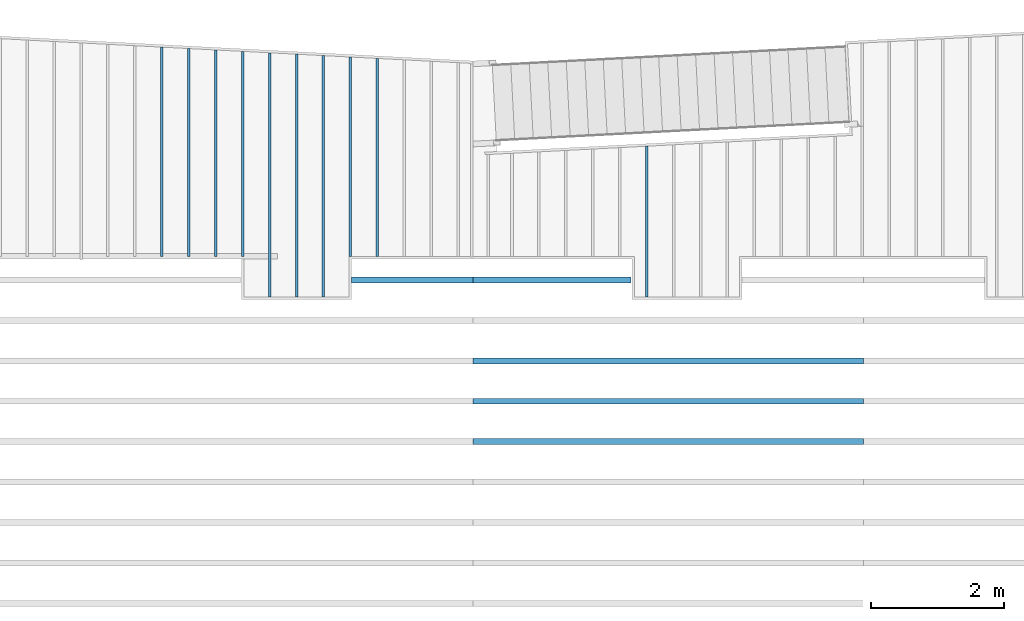
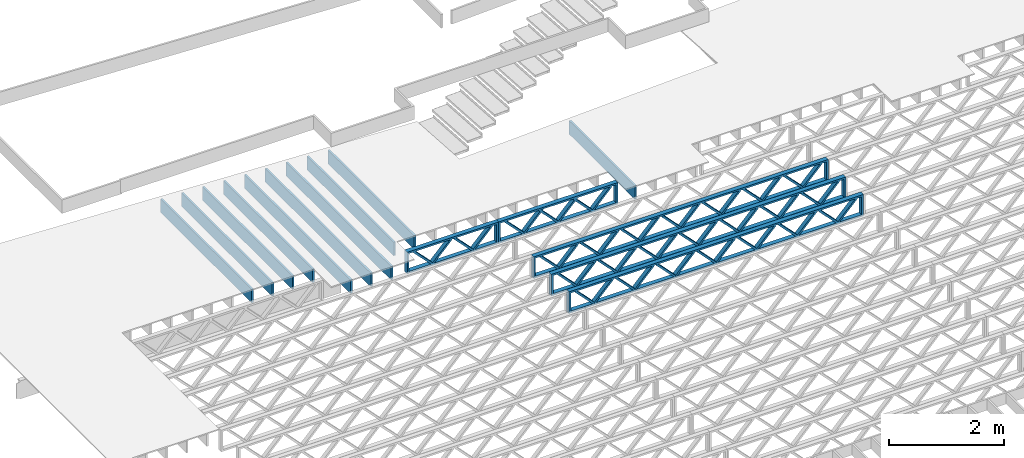
# One storey, part 4 of 23: 15 beams, 3 elements without a shape of their own.
"""IFC4 building model written with IfcOpenShell, lengths in feet."""

from ifc_helpers import new_model, entity, si_unit, converted_unit, derived_unit, direction, frame, frame_2d, origin, origin_2d_with_axis, place, context, subcontext, project, spatial, rectangle, extrude, source, transform, mapped, material, material_profile, profile_set, profile_usage, type_object, type_shapes, element, aggregate, save


model = new_model("IFC4")

# Units and contexts
model_context_1 = context("Model", 3, precision=0.0001, world=origin(), true_north=direction((6.12303176911189e-17, 1.0)))
model_context_2 = context("Model", 3, precision=0.0001, world=origin(), true_north=direction((6.12303176911189e-17, 1.0)))
body_context = subcontext(model_context_2, "Body", "Model", "MODEL_VIEW")
ifc_project = project(units=[converted_unit("LENGTHUNIT", "FOOT", entity("IfcRatioMeasure", 0.3048), si_unit("LENGTHUNIT", "METRE"), dimensions=[1, 0, 0, 0, 0, 0, 0]), converted_unit("AREAUNIT", "SQUARE FOOT", entity("IfcRatioMeasure", 0.09290304), si_unit("AREAUNIT", "SQUARE_METRE"), dimensions=[2, 0, 0, 0, 0, 0, 0]), converted_unit("VOLUMEUNIT", "CUBIC FOOT", entity("IfcRatioMeasure", 0.028316846592), si_unit("VOLUMEUNIT", "CUBIC_METRE"), dimensions=[3, 0, 0, 0, 0, 0, 0]), converted_unit("PLANEANGLEUNIT", "DEGREE", entity("IfcRatioMeasure", 0.0174532925199433), si_unit("PLANEANGLEUNIT", "RADIAN"), dimensions=[0, 0, 0, 0, 0, 0, 0]), si_unit("MASSUNIT", "GRAM", prefix="KILO"), derived_unit("MASSDENSITYUNIT", [(si_unit("MASSUNIT", "GRAM", prefix="KILO"), 1), (si_unit("LENGTHUNIT", "METRE"), -3)]), derived_unit("MOMENTOFINERTIAUNIT", [(si_unit("LENGTHUNIT", "METRE"), 4)]), si_unit("TIMEUNIT", "SECOND"), si_unit("FREQUENCYUNIT", "HERTZ"), si_unit("THERMODYNAMICTEMPERATUREUNIT", "DEGREE_CELSIUS"), derived_unit("THERMALTRANSMITTANCEUNIT", [(si_unit("MASSUNIT", "GRAM", prefix="KILO"), 1), (si_unit("THERMODYNAMICTEMPERATUREUNIT", "KELVIN"), -1), (si_unit("TIMEUNIT", "SECOND"), -3)]), derived_unit("VOLUMETRICFLOWRATEUNIT", [(si_unit("LENGTHUNIT", "METRE"), 3), (si_unit("TIMEUNIT", "SECOND"), -1)]), si_unit("ELECTRICCURRENTUNIT", "AMPERE"), si_unit("ELECTRICVOLTAGEUNIT", "VOLT"), si_unit("POWERUNIT", "WATT"), si_unit("FORCEUNIT", "NEWTON"), si_unit("ILLUMINANCEUNIT", "LUX"), si_unit("LUMINOUSFLUXUNIT", "LUMEN"), si_unit("LUMINOUSINTENSITYUNIT", "CANDELA"), derived_unit("USERDEFINED", [(si_unit("MASSUNIT", "GRAM", prefix="KILO"), -1), (si_unit("LENGTHUNIT", "METRE"), -2), (si_unit("TIMEUNIT", "SECOND"), 3), (si_unit("LUMINOUSFLUXUNIT", "LUMEN"), 1)]), derived_unit("LINEARVELOCITYUNIT", [(si_unit("LENGTHUNIT", "METRE"), 1), (si_unit("TIMEUNIT", "SECOND"), -1)]), si_unit("PRESSUREUNIT", "PASCAL"), derived_unit("USERDEFINED", [(si_unit("LENGTHUNIT", "METRE"), -2), (si_unit("MASSUNIT", "GRAM", prefix="KILO"), 1), (si_unit("TIMEUNIT", "SECOND"), -2)]), derived_unit("LINEARFORCEUNIT", [(si_unit("MASSUNIT", "GRAM", prefix="KILO"), 1), (si_unit("LENGTHUNIT", "METRE"), 1), (si_unit("TIMEUNIT", "SECOND"), -2), (si_unit("LENGTHUNIT", "METRE"), -1)]), derived_unit("PLANARFORCEUNIT", [(si_unit("MASSUNIT", "GRAM", prefix="KILO"), 1), (si_unit("LENGTHUNIT", "METRE"), 1), (si_unit("TIMEUNIT", "SECOND"), -2), (si_unit("LENGTHUNIT", "METRE"), -2)])], contexts=[model_context_1])

# Site, building, storey
site_placement = place(None, origin())
site = spatial("IfcSite", under=ifc_project, at=site_placement, CompositionType="ELEMENT")
building_placement = place(site_placement, origin())
building = spatial("IfcBuilding", under=site, at=building_placement, CompositionType="ELEMENT")
storey_placement = place(building_placement, frame((0.0, 0.0, 10.8020833333333)))
storey = spatial("IfcBuildingStorey", under=building, at=storey_placement, Name="2ND FLOOR", CompositionType="ELEMENT", Elevation=10.8020833333333)

# Assembly, beams
assembly_1_placement = place(storey_placement, origin())
assembly_1 = element("IfcElementAssembly", 1, at=assembly_1_placement, inside=storey, Name="Structural Beam System:Structural Framing System", ObjectType="Structural Beam System:Structural Framing System", AssemblyPlace="NOTDEFINED", PredefinedType="BEAM_GRID")
ifc_material_1 = material(Category="Materials")
ifc_material_profile_1 = material_profile(ifc_material_1, rectangle(XDim=0.9375, YDim=0.125000000000011, at=origin_2d_with_axis()))
ifc_profile_set_1 = profile_set([ifc_material_profile_1])
ifc_profile_usage_1 = profile_usage(ifc_profile_set_1, cardinal=8)
beam_type_1 = type_object("IfcBeamType", PredefinedType="BEAM", material=ifc_profile_set_1)
shared_shape_1 = source(origin(), body_context, "Body", "SweptSolid", [
    extrude(rectangle(XDim=0.9375, YDim=0.125000000000011, at=origin_2d_with_axis()), frame((-3.72929415572452, 0.0, 0.0), z_axis=(1.0, 0.0, 0.0), x_axis=(0.0, 0.0, -1.0)), (0.0, 0.0, 1.0), 7.45858831144903),
])
type_shapes(beam_type_1, [shared_shape_1])
beam_1_placement = place(assembly_1_placement, frame((-233.133993818795, 960.757895705042, -0.729166666666744), z_axis=(0.0, 0.0, 1.0), x_axis=(0.0, 1.0, 0.0)))
beam_1 = element("IfcBeam", 2, at=beam_1_placement, type_object=beam_type_1, material=ifc_profile_usage_1, PredefinedType="BEAM", context=body_context, shape_type="MappedRepresentation", body=[
    mapped(shared_shape_1, transform((0.0, 0.0, 0.0), scale=1.0)),
])
ifc_profile_usage_2 = profile_usage(ifc_profile_set_1, cardinal=8)
beam_type_2 = type_object("IfcBeamType", PredefinedType="BEAM", material=ifc_profile_set_1)
shared_shape_2 = source(origin(), body_context, "Body", "SweptSolid", [
    extrude(rectangle(XDim=0.9375, YDim=0.125000000000011, at=origin_2d_with_axis()), frame((-4.90124353989279, 0.0, 0.0), z_axis=(1.0, 0.0, 0.0), x_axis=(0.0, 0.0, -1.0)), (0.0, 0.0, 1.0), 9.80248707978558),
])
type_shapes(beam_type_2, [shared_shape_2])
beam_2_placement = place(assembly_1_placement, frame((-246.467327152129, 963.929847709559, -0.729166666666744), z_axis=(0.0, 0.0, 1.0), x_axis=(0.0, 1.0, 0.0)))
beam_2 = element("IfcBeam", 3, at=beam_2_placement, type_object=beam_type_2, material=ifc_profile_usage_2, PredefinedType="BEAM", context=body_context, shape_type="MappedRepresentation", body=[
    mapped(shared_shape_2, transform((0.0, 0.0, 0.0), scale=1.0)),
])
ifc_profile_usage_3 = profile_usage(ifc_profile_set_1, cardinal=8)
beam_type_3 = type_object("IfcBeamType", PredefinedType="BEAM", material=ifc_profile_set_1)
shared_shape_3 = source(origin(), body_context, "Body", "SweptSolid", [
    extrude(rectangle(XDim=0.9375, YDim=0.125000000000011, at=origin_2d_with_axis()), frame((-6.04099892815498, 0.0, 0.0), z_axis=(1.0, 0.0, 0.0), x_axis=(0.0, 0.0, -1.0)), (0.0, 0.0, 1.0), 12.08199785631),
])
type_shapes(beam_type_3, [shared_shape_3])
beam_3_placement = place(assembly_1_placement, frame((-251.800660485462, 963.069600477473, -0.729166666666744), z_axis=(0.0, 0.0, 1.0), x_axis=(0.0, 1.0, 0.0)))
beam_3 = element("IfcBeam", 4, at=beam_3_placement, type_object=beam_type_3, material=ifc_profile_usage_3, PredefinedType="BEAM", context=body_context, shape_type="MappedRepresentation", body=[
    mapped(shared_shape_3, transform((0.0, 0.0, 0.0), scale=1.0)),
])
ifc_profile_usage_4 = profile_usage(ifc_profile_set_1, cardinal=8)
beam_type_4 = type_object("IfcBeamType", PredefinedType="BEAM", material=ifc_profile_set_1)
shared_shape_4 = source(origin(), body_context, "Body", "SweptSolid", [
    extrude(rectangle(XDim=0.9375, YDim=0.125000000000011, at=origin_2d_with_axis()), frame((-5.11087465702491, 0.0, 0.0), z_axis=(1.0, 0.0, 0.0), x_axis=(0.0, 0.0, -1.0)), (0.0, 0.0, 1.0), 10.2217493140498),
])
type_shapes(beam_type_4, [shared_shape_4])
beam_4_placement = place(assembly_1_placement, frame((-254.467327152129, 964.139478826691, -0.729166666666744), z_axis=(0.0, 0.0, 1.0), x_axis=(0.0, 1.0, 0.0)))
beam_4 = element("IfcBeam", 5, at=beam_4_placement, type_object=beam_type_4, material=ifc_profile_usage_4, PredefinedType="BEAM", context=body_context, shape_type="MappedRepresentation", body=[
    mapped(shared_shape_4, transform((0.0, 0.0, 0.0), scale=1.0)),
])

assembly_2_placement = place(storey_placement, origin())
assembly_2 = element("IfcElementAssembly", 6, at=assembly_2_placement, inside=storey, Name="Structural Beam System:Structural Framing System", ObjectType="Structural Beam System:Structural Framing System", AssemblyPlace="NOTDEFINED", PredefinedType="BEAM_GRID")
ifc_material_2 = material(Name="WOOD TRUSS", Category="Materials")
ifc_material_profile_2 = material_profile(ifc_material_2, rectangle(XDim=1.73473973950632, YDim=0.125, at=frame_2d((-1.11022302462516e-16, 8.32667268468867e-17), x_axis=(1.0, 0.0))))
ifc_material_profile_3 = material_profile(ifc_material_2, rectangle(XDim=1.73473973950633, YDim=0.125, at=frame_2d((-1.11022302462516e-16, 8.32667268468867e-17), x_axis=(1.0, 0.0))))
ifc_material_profile_4 = material_profile(ifc_material_2, rectangle(XDim=1.73473973950632, YDim=0.125, at=frame_2d((-5.55111512312578e-17, 1.38777878078145e-16), x_axis=(1.0, 0.0))))
ifc_material_profile_5 = material_profile(ifc_material_2, rectangle(XDim=1.73473973950633, YDim=0.125, at=frame_2d((-1.11022302462516e-16, 8.32667268468867e-17), x_axis=(1.0, 0.0))))
ifc_material_profile_6 = material_profile(ifc_material_2, rectangle(XDim=1.73473973950632, YDim=0.125, at=frame_2d((-1.11022302462516e-16, 8.32667268468867e-17), x_axis=(1.0, 0.0))))
ifc_material_profile_7 = material_profile(ifc_material_2, rectangle(XDim=1.73473973950633, YDim=0.125, at=frame_2d((-2.77555756156289e-16, 3.05311331771918e-16), x_axis=(1.0, 0.0))))
ifc_material_profile_8 = material_profile(ifc_material_2, rectangle(XDim=1.73473973950632, YDim=0.124999999999999, at=frame_2d((-3.88578058618805e-16, -2.4980018054066e-16), x_axis=(1.0, 0.0))))
ifc_material_profile_9 = material_profile(ifc_material_2, rectangle(XDim=1.73473973950633, YDim=0.125, at=frame_2d((2.77555756156289e-16, -3.05311331771918e-16), x_axis=(1.0, 0.0))))
ifc_material_profile_10 = material_profile(ifc_material_2, rectangle(XDim=1.73473973950632, YDim=0.124999999999999, at=frame_2d((-1.11022302462516e-16, 8.32667268468867e-17), x_axis=(1.0, 0.0))))
ifc_material_profile_11 = material_profile(ifc_material_2, rectangle(XDim=1.73473973950633, YDim=0.125, at=origin_2d_with_axis()))
ifc_material_profile_12 = material_profile(ifc_material_2, rectangle(XDim=0.124999999999982, YDim=0.291666666666668, at=origin_2d_with_axis()))
ifc_material_profile_13 = material_profile(ifc_material_2, rectangle(XDim=0.124999999999932, YDim=0.291666666666664, at=origin_2d_with_axis()))
ifc_material_profile_14 = material_profile(ifc_material_2, rectangle(XDim=1.25000000000002, YDim=0.29166666666667, at=origin_2d_with_axis()))
ifc_material_profile_15 = material_profile(ifc_material_2, rectangle(XDim=1.25000000000004, YDim=0.291666666666667, at=origin_2d_with_axis()))
ifc_profile_set_2 = profile_set([ifc_material_profile_2, ifc_material_profile_3, ifc_material_profile_4, ifc_material_profile_5, ifc_material_profile_6, ifc_material_profile_7, ifc_material_profile_8, ifc_material_profile_9, ifc_material_profile_10, ifc_material_profile_11, ifc_material_profile_12, ifc_material_profile_13, ifc_material_profile_14, ifc_material_profile_15])
ifc_profile_usage_5 = profile_usage(ifc_profile_set_2, cardinal=8)
beam_type_5 = type_object("IfcBeamType", PredefinedType="BEAM", material=ifc_profile_set_2)
shared_shape_5 = source(origin(), body_context, "Body", "SweptSolid", [
    extrude(rectangle(XDim=1.73473973950632, YDim=0.124999999999999, at=frame_2d((5.55111512312578e-16, 7.21644966006352e-16), x_axis=(1.0, 0.0))), frame((5.95847627016997, -0.145833333333334, 0.0), z_axis=(0.0, 1.0, 0.0), x_axis=(0.693383046997606, 0.0, 0.720569184836762)), (0.0, 0.0, 1.0), 0.291666666666667),
    extrude(rectangle(XDim=1.73473973950633, YDim=0.125, at=origin_2d_with_axis()), frame((4.7081903964967, -0.145833333333334, 0.0), z_axis=(0.0, 1.0, 0.0), x_axis=(0.69338304699761, 0.0, -0.720569184836758)), (0.0, 0.0, 1.0), 0.291666666666666),
    extrude(rectangle(XDim=1.73473973950632, YDim=0.125, at=frame_2d((2.22044604925031e-16, 3.88578058618805e-16), x_axis=(1.0, 0.0))), frame((3.29180960350347, -0.145833333333334, 0.0), z_axis=(0.0, 1.0, 0.0), x_axis=(0.693383046997606, 0.0, 0.720569184836762)), (0.0, 0.0, 1.0), 0.291666666666667),
    extrude(rectangle(XDim=1.73473973950633, YDim=0.125, at=frame_2d((1.11022302462516e-16, -8.32667268468867e-17), x_axis=(1.0, 0.0))), frame((2.0415237298302, -0.145833333333334, 0.0), z_axis=(0.0, 1.0, 0.0), x_axis=(0.69338304699761, 0.0, -0.720569184836758)), (0.0, 0.0, 1.0), 0.291666666666667),
    extrude(rectangle(XDim=1.73473973950632, YDim=0.125, at=frame_2d((-5.55111512312578e-17, 1.38777878078145e-16), x_axis=(1.0, 0.0))), frame((0.625142936836964, -0.145833333333334, 0.0), z_axis=(0.0, 1.0, 0.0), x_axis=(0.693383046997606, 0.0, 0.720569184836762)), (0.0, 0.0, 1.0), 0.291666666666667),
    extrude(rectangle(XDim=1.73473973950633, YDim=0.125, at=frame_2d((-1.11022302462516e-16, 8.32667268468867e-17), x_axis=(1.0, 0.0))), frame((-0.625142936836306, -0.145833333333334, 0.0), z_axis=(0.0, 1.0, 0.0), x_axis=(0.69338304699761, 0.0, -0.720569184836758)), (0.0, 0.0, 1.0), 0.291666666666667),
    extrude(rectangle(XDim=1.73473973950632, YDim=0.125, at=frame_2d((-1.11022302462516e-16, 8.32667268468867e-17), x_axis=(1.0, 0.0))), frame((-2.04152372982954, -0.145833333333334, 0.0), z_axis=(0.0, 1.0, 0.0), x_axis=(0.693383046997606, 0.0, 0.720569184836762)), (0.0, 0.0, 1.0), 0.291666666666667),
    extrude(rectangle(XDim=1.73473973950633, YDim=0.125, at=origin_2d_with_axis()), frame((-3.29180960350281, -0.145833333333334, 0.0), z_axis=(0.0, 1.0, 0.0), x_axis=(0.69338304699761, 0.0, -0.720569184836758)), (0.0, 0.0, 1.0), 0.291666666666667),
    extrude(rectangle(XDim=1.73473973950632, YDim=0.124999999999999, at=frame_2d((-1.11022302462516e-16, 8.32667268468867e-17), x_axis=(1.0, 0.0))), frame((-4.70819039649604, -0.145833333333334, 0.0), z_axis=(0.0, 1.0, 0.0), x_axis=(0.693383046997606, 0.0, 0.720569184836762)), (0.0, 0.0, 1.0), 0.291666666666667),
    extrude(rectangle(XDim=1.73473973950633, YDim=0.125, at=frame_2d((-5.55111512312578e-16, 6.38378239159465e-16), x_axis=(1.0, 0.0))), frame((-5.95847627016931, -0.145833333333334, 0.0), z_axis=(0.0, 1.0, 0.0), x_axis=(0.69338304699761, 0.0, -0.720569184836758)), (0.0, 0.0, 1.0), 0.291666666666666),
    extrude(rectangle(XDim=1.73473973950632, YDim=0.125, at=frame_2d((-7.21644966006352e-16, -5.82867087928207e-16), x_axis=(1.0, 0.0))), frame((8.62514293683647, -0.145833333333334, 0.0), z_axis=(0.0, 1.0, 0.0), x_axis=(0.693383046997607, 0.0, 0.720569184836761)), (0.0, 0.0, 1.0), 0.291666666666667),
    extrude(rectangle(XDim=1.73473973950633, YDim=0.125, at=origin_2d_with_axis()), frame((7.3748570631632, -0.145833333333334, 0.0), z_axis=(0.0, 1.0, 0.0), x_axis=(0.69338304699761, 0.0, -0.720569184836758)), (0.0, 0.0, 1.0), 0.291666666666666),
    extrude(rectangle(XDim=1.73473973950632, YDim=0.124999999999999, at=frame_2d((-1.11022302462516e-16, 8.32667268468867e-17), x_axis=(1.0, 0.0))), frame((-7.37485706316255, -0.145833333333334, 0.0), z_axis=(0.0, 1.0, 0.0), x_axis=(0.693383046997606, 0.0, 0.720569184836762)), (0.0, 0.0, 1.0), 0.291666666666667),
    extrude(rectangle(XDim=1.73473973950633, YDim=0.125, at=origin_2d_with_axis()), frame((-8.62514293683582, -0.145833333333334, 0.0), z_axis=(0.0, 1.0, 0.0), x_axis=(0.69338304699761, 0.0, -0.720569184836758)), (0.0, 0.0, 1.0), 0.291666666666666),
    extrude(rectangle(XDim=0.124999999999982, YDim=0.291666666666668, at=origin_2d_with_axis()), frame((-9.66666666666609, 0.0, 0.687500000000054), z_axis=(1.0, 0.0, 0.0), x_axis=(0.0, 0.0, -1.0)), (0.0, 0.0, 1.0), 19.3333333333322),
    extrude(rectangle(XDim=0.124999999999932, YDim=0.291666666666664, at=origin_2d_with_axis()), frame((-9.66666666666588, 0.0, -0.687499999999984), z_axis=(1.0, 0.0, 0.0), x_axis=(0.0, 0.0, -1.0)), (0.0, 0.0, 1.0), 19.333333333332),
    extrude(rectangle(XDim=1.25000000000002, YDim=0.29166666666667, at=origin_2d_with_axis()), frame((9.54166666666607, 0.0, 0.0), z_axis=(1.0, 0.0, 0.0), x_axis=(0.0, 0.0, -1.0)), (0.0, 0.0, 1.0), 0.12500000000002),
    extrude(rectangle(XDim=1.25000000000004, YDim=0.291666666666667, at=origin_2d_with_axis()), frame((-9.66666666666609, 0.0, 0.0), z_axis=(1.0, 0.0, 0.0), x_axis=(0.0, 0.0, -1.0)), (0.0, 0.0, 1.0), 0.125000000000023),
])
type_shapes(beam_type_5, [shared_shape_5])
beam_5_placement = place(assembly_2_placement, frame((-232.071493788723, 953.861934882651, -0.947916666666657)))
beam_5 = element("IfcBeam", 7, at=beam_5_placement, type_object=beam_type_5, material=ifc_profile_usage_5, PredefinedType="BEAM", context=body_context, shape_type="MappedRepresentation", body=[
    mapped(shared_shape_5, transform((0.0, 0.0, 0.0), scale=1.0)),
])
ifc_profile_usage_6 = profile_usage(ifc_profile_set_2, cardinal=8)
beam_6_placement = place(assembly_2_placement, frame((-232.071493788723, 951.861934882651, -0.947916666666657)))
beam_6 = element("IfcBeam", 8, at=beam_6_placement, type_object=beam_type_5, material=ifc_profile_usage_6, PredefinedType="BEAM", context=body_context, shape_type="MappedRepresentation", body=[
    mapped(shared_shape_5, transform((0.0, 0.0, 0.0), scale=1.0)),
])
ifc_profile_usage_7 = profile_usage(ifc_profile_set_2, cardinal=8)
beam_7_placement = place(assembly_2_placement, frame((-232.071493788723, 949.861934882651, -0.947916666666657)))
beam_7 = element("IfcBeam", 9, at=beam_7_placement, type_object=beam_type_5, material=ifc_profile_usage_7, PredefinedType="BEAM", context=body_context, shape_type="MappedRepresentation", body=[
    mapped(shared_shape_5, transform((0.0, 0.0, 0.0), scale=1.0)),
])
ifc_profile_usage_8 = profile_usage(ifc_profile_set_2, cardinal=8)
beam_type_6 = type_object("IfcBeamType", PredefinedType="BEAM", material=ifc_profile_set_2)
shared_shape_6 = source(origin(), body_context, "Body", "SweptSolid", [
    extrude(rectangle(XDim=1.73473973950632, YDim=0.125, at=frame_2d((-5.55111512312578e-17, 1.38777878078145e-16), x_axis=(1.0, 0.0))), frame((0.625142936836962, -0.145833333333334, 0.0), z_axis=(0.0, 1.0, 0.0), x_axis=(0.693383046997606, 0.0, 0.720569184836762)), (0.0, 0.0, 1.0), 0.291666666666667),
    extrude(rectangle(XDim=1.73473973950633, YDim=0.125, at=frame_2d((-1.11022302462516e-16, 8.32667268468867e-17), x_axis=(1.0, 0.0))), frame((-0.625142936836309, -0.145833333333334, 0.0), z_axis=(0.0, 1.0, 0.0), x_axis=(0.69338304699761, 0.0, -0.720569184836758)), (0.0, 0.0, 1.0), 0.291666666666667),
    extrude(rectangle(XDim=1.73473973950632, YDim=0.125, at=frame_2d((-1.11022302462516e-16, 8.32667268468867e-17), x_axis=(1.0, 0.0))), frame((2.87514283803796, -0.145833333333334, 0.0), z_axis=(0.0, 1.0, 0.0), x_axis=(0.693383046997606, 0.0, 0.720569184836762)), (0.0, 0.0, 1.0), 0.291666666666667),
    extrude(rectangle(XDim=1.73473973950633, YDim=0.125, at=frame_2d((-1.11022302462516e-16, 8.32667268468867e-17), x_axis=(1.0, 0.0))), frame((1.62485696436469, -0.145833333333334, 0.0), z_axis=(0.0, 1.0, 0.0), x_axis=(0.69338304699761, 0.0, -0.720569184836758)), (0.0, 0.0, 1.0), 0.291666666666667),
    extrude(rectangle(XDim=1.73473973950632, YDim=0.125, at=frame_2d((-1.11022302462516e-16, 8.32667268468867e-17), x_axis=(1.0, 0.0))), frame((-1.62485696436403, -0.145833333333334, 0.0), z_axis=(0.0, 1.0, 0.0), x_axis=(0.693383046997606, 0.0, 0.720569184836762)), (0.0, 0.0, 1.0), 0.291666666666667),
    extrude(rectangle(XDim=1.73473973950633, YDim=0.125, at=origin_2d_with_axis()), frame((-2.87514283803731, -0.145833333333334, 0.0), z_axis=(0.0, 1.0, 0.0), x_axis=(0.69338304699761, 0.0, -0.720569184836758)), (0.0, 0.0, 1.0), 0.291666666666667),
    extrude(rectangle(XDim=0.124999999999982, YDim=0.291666666666668, at=origin_2d_with_axis()), frame((-3.91666656786758, 0.0, 0.687500000000054), z_axis=(1.0, 0.0, 0.0), x_axis=(0.0, 0.0, -1.0)), (0.0, 0.0, 1.0), 7.83333313573516),
    extrude(rectangle(XDim=0.124999999999932, YDim=0.291666666666664, at=origin_2d_with_axis()), frame((-3.91666656786737, 0.0, -0.687499999999984), z_axis=(1.0, 0.0, 0.0), x_axis=(0.0, 0.0, -1.0)), (0.0, 0.0, 1.0), 7.83333313573495),
    extrude(rectangle(XDim=1.25000000000002, YDim=0.29166666666667, at=origin_2d_with_axis()), frame((3.79166656786756, 0.0, 0.0), z_axis=(1.0, 0.0, 0.0), x_axis=(0.0, 0.0, -1.0)), (0.0, 0.0, 1.0), 0.12500000000002),
    extrude(rectangle(XDim=1.25000000000004, YDim=0.291666666666667, at=origin_2d_with_axis()), frame((-3.91666656786758, 0.0, 0.0), z_axis=(1.0, 0.0, 0.0), x_axis=(0.0, 0.0, -1.0)), (0.0, 0.0, 1.0), 0.125000000000023),
])
type_shapes(beam_type_6, [shared_shape_6])
beam_8_placement = place(assembly_2_placement, frame((-237.821493887522, 957.861934882651, -0.947916666666657)))
beam_8 = element("IfcBeam", 10, at=beam_8_placement, type_object=beam_type_6, material=ifc_profile_usage_8, PredefinedType="BEAM", context=body_context, shape_type="MappedRepresentation", body=[
    mapped(shared_shape_6, transform((0.0, 0.0, 0.0), scale=1.0)),
])
aggregate(assembly_2, [beam_5, beam_6, beam_7, beam_8])

# Beam
ifc_profile_usage_9 = profile_usage(ifc_profile_set_1, cardinal=8)
beam_type_7 = type_object("IfcBeamType", PredefinedType="BEAM", material=ifc_profile_set_1)
shared_shape_7 = source(origin(), body_context, "Body", "SweptSolid", [
    extrude(rectangle(XDim=0.9375, YDim=0.125000000000011, at=origin_2d_with_axis()), frame((-5.97112188911098, 0.0, 0.0), z_axis=(1.0, 0.0, 0.0), x_axis=(0.0, 0.0, -1.0)), (0.0, 0.0, 1.0), 11.942243778222),
])
type_shapes(beam_type_7, [shared_shape_7])
beam_9_placement = place(assembly_1_placement, frame((-249.133993818795, 962.999723438429, -0.729166666666744), z_axis=(0.0, 0.0, 1.0), x_axis=(0.0, 1.0, 0.0)))
beam_9 = element("IfcBeam", 11, at=beam_9_placement, type_object=beam_type_7, material=ifc_profile_usage_9, PredefinedType="BEAM", context=body_context, shape_type="MappedRepresentation", body=[
    mapped(shared_shape_7, transform((0.0, 0.0, 0.0), scale=1.0)),
])

ifc_profile_usage_10 = profile_usage(ifc_profile_set_1, cardinal=8)
beam_type_8 = type_object("IfcBeamType", PredefinedType="BEAM", material=ifc_profile_set_1)
shared_shape_8 = source(origin(), body_context, "Body", "SweptSolid", [
    extrude(rectangle(XDim=0.9375, YDim=0.125000000000011, at=origin_2d_with_axis()), frame((-5.18075169606897, 0.0, 0.0), z_axis=(1.0, 0.0, 0.0), x_axis=(0.0, 0.0, -1.0)), (0.0, 0.0, 1.0), 10.3615033921379),
])
type_shapes(beam_type_8, [shared_shape_8])
beam_10_placement = place(assembly_1_placement, frame((-257.133993818795, 964.209355865735, -0.729166666666744), z_axis=(0.0, 0.0, 1.0), x_axis=(0.0, 1.0, 0.0)))
beam_10 = element("IfcBeam", 12, at=beam_10_placement, type_object=beam_type_8, material=ifc_profile_usage_10, PredefinedType="BEAM", context=body_context, shape_type="MappedRepresentation", body=[
    mapped(shared_shape_8, transform((0.0, 0.0, 0.0), scale=1.0)),
])

ifc_profile_usage_11 = profile_usage(ifc_profile_set_1, cardinal=8)
beam_type_9 = type_object("IfcBeamType", PredefinedType="BEAM", material=ifc_profile_set_1)
shared_shape_9 = source(origin(), body_context, "Body", "SweptSolid", [
    extrude(rectangle(XDim=0.9375, YDim=0.125000000000011, at=origin_2d_with_axis()), frame((-5.14581317654694, 0.0, 0.0), z_axis=(1.0, 0.0, 0.0), x_axis=(0.0, 0.0, -1.0)), (0.0, 0.0, 1.0), 10.2916263530939),
])
type_shapes(beam_type_9, [shared_shape_9])
beam_11_placement = place(assembly_1_placement, frame((-255.800660485462, 964.174417346213, -0.729166666666744), z_axis=(0.0, 0.0, 1.0), x_axis=(0.0, 1.0, 0.0)))
beam_11 = element("IfcBeam", 13, at=beam_11_placement, type_object=beam_type_9, material=ifc_profile_usage_11, PredefinedType="BEAM", context=body_context, shape_type="MappedRepresentation", body=[
    mapped(shared_shape_9, transform((0.0, 0.0, 0.0), scale=1.0)),
])

ifc_profile_usage_12 = profile_usage(ifc_profile_set_1, cardinal=8)
beam_type_10 = type_object("IfcBeamType", PredefinedType="BEAM", material=ifc_profile_set_1)
shared_shape_10 = source(origin(), body_context, "Body", "SweptSolid", [
    extrude(rectangle(XDim=0.9375, YDim=0.125000000000011, at=origin_2d_with_axis()), frame((-5.07593613750288, 0.0, 0.0), z_axis=(1.0, 0.0, 0.0), x_axis=(0.0, 0.0, -1.0)), (0.0, 0.0, 1.0), 10.1518722750058),
])
type_shapes(beam_type_10, [shared_shape_10])
beam_12_placement = place(assembly_1_placement, frame((-253.133993818795, 964.104540307169, -0.729166666666744), z_axis=(0.0, 0.0, 1.0), x_axis=(0.0, 1.0, 0.0)))
beam_12 = element("IfcBeam", 14, at=beam_12_placement, type_object=beam_type_10, material=ifc_profile_usage_12, PredefinedType="BEAM", context=body_context, shape_type="MappedRepresentation", body=[
    mapped(shared_shape_10, transform((0.0, 0.0, 0.0), scale=1.0)),
])

ifc_profile_usage_13 = profile_usage(ifc_profile_set_1, cardinal=8)
beam_type_11 = type_object("IfcBeamType", PredefinedType="BEAM", material=ifc_profile_set_1)
shared_shape_11 = source(origin(), body_context, "Body", "SweptSolid", [
    extrude(rectangle(XDim=0.9375, YDim=0.125000000000011, at=origin_2d_with_axis()), frame((-6.006060408633, 0.0, 0.0), z_axis=(1.0, 0.0, 0.0), x_axis=(0.0, 0.0, -1.0)), (0.0, 0.0, 1.0), 12.012120817266),
])
type_shapes(beam_type_11, [shared_shape_11])
beam_13_placement = place(assembly_1_placement, frame((-250.467327152129, 963.034661957951, -0.729166666666744), z_axis=(0.0, 0.0, 1.0), x_axis=(0.0, 1.0, 0.0)))
beam_13 = element("IfcBeam", 15, at=beam_13_placement, type_object=beam_type_11, material=ifc_profile_usage_13, PredefinedType="BEAM", context=body_context, shape_type="MappedRepresentation", body=[
    mapped(shared_shape_11, transform((0.0, 0.0, 0.0), scale=1.0)),
])

ifc_profile_usage_14 = profile_usage(ifc_profile_set_1, cardinal=8)
beam_type_12 = type_object("IfcBeamType", PredefinedType="BEAM", material=ifc_profile_set_1)
shared_shape_12 = source(origin(), body_context, "Body", "SweptSolid", [
    extrude(rectangle(XDim=0.9375, YDim=0.125000000000011, at=origin_2d_with_axis()), frame((-4.93618205941482, 0.0, 0.0), z_axis=(1.0, 0.0, 0.0), x_axis=(0.0, 0.0, -1.0)), (0.0, 0.0, 1.0), 9.87236411882964),
])
type_shapes(beam_type_12, [shared_shape_12])
beam_14_placement = place(assembly_1_placement, frame((-247.800660485462, 963.964786229081, -0.729166666666744), z_axis=(0.0, 0.0, 1.0), x_axis=(0.0, 1.0, 0.0)))
beam_14 = element("IfcBeam", 16, at=beam_14_placement, type_object=beam_type_12, material=ifc_profile_usage_14, PredefinedType="BEAM", context=body_context, shape_type="MappedRepresentation", body=[
    mapped(shared_shape_12, transform((0.0, 0.0, 0.0), scale=1.0)),
])

aggregate(assembly_1, [beam_1, beam_2, beam_3, beam_4, beam_9, beam_10, beam_11, beam_12, beam_13, beam_14])

# Assembly, beam
assembly_3_placement = place(storey_placement, origin())
assembly_3 = element("IfcElementAssembly", 17, at=assembly_3_placement, inside=storey, Name="Structural Beam System:Structural Framing System", ObjectType="Structural Beam System:Structural Framing System", AssemblyPlace="NOTDEFINED", PredefinedType="BEAM_GRID")
ifc_profile_usage_15 = profile_usage(ifc_profile_set_2, cardinal=8)
beam_type_13 = type_object("IfcBeamType", PredefinedType="BEAM", material=ifc_profile_set_2)
shared_shape_13 = source(origin(), body_context, "Body", "SweptSolid", [
    extrude(rectangle(XDim=1.73473973950632, YDim=0.125, at=frame_2d((0.0, 1.66533453693773e-16), x_axis=(1.0, 0.0))), frame((1.95847576769603, -0.145833333333334, 0.0), z_axis=(0.0, 1.0, 0.0), x_axis=(0.693383046997606, 0.0, 0.720569184836762)), (0.0, 0.0, 1.0), 0.291666666666667),
    extrude(rectangle(XDim=1.73473973950633, YDim=0.125, at=frame_2d((-5.55111512312578e-17, 8.32667268468867e-17), x_axis=(1.0, 0.0))), frame((0.708189894022761, -0.145833333333334, 0.0), z_axis=(0.0, 1.0, 0.0), x_axis=(0.69338304699761, 0.0, -0.720569184836758)), (0.0, 0.0, 1.0), 0.291666666666667),
    extrude(rectangle(XDim=1.73473973950632, YDim=0.125, at=frame_2d((0.0, 1.66533453693773e-16), x_axis=(1.0, 0.0))), frame((-0.708189894022106, -0.145833333333334, 0.0), z_axis=(0.0, 1.0, 0.0), x_axis=(0.693383046997606, 0.0, 0.720569184836762)), (0.0, 0.0, 1.0), 0.291666666666667),
    extrude(rectangle(XDim=1.73473973950633, YDim=0.125, at=frame_2d((-2.22044604925031e-16, 2.22044604925031e-16), x_axis=(1.0, 0.0))), frame((-1.95847576769538, -0.145833333333334, 0.0), z_axis=(0.0, 1.0, 0.0), x_axis=(0.69338304699761, 0.0, -0.720569184836758)), (0.0, 0.0, 1.0), 0.291666666666666),
    extrude(rectangle(XDim=0.124999999999982, YDim=0.291666666666668, at=origin_2d_with_axis()), frame((-2.99999949752565, 0.0, 0.687500000000054), z_axis=(1.0, 0.0, 0.0), x_axis=(0.0, 0.0, -1.0)), (0.0, 0.0, 1.0), 5.9999989950513),
    extrude(rectangle(XDim=0.124999999999932, YDim=0.291666666666664, at=origin_2d_with_axis()), frame((-2.99999949752544, 0.0, -0.687499999999984), z_axis=(1.0, 0.0, 0.0), x_axis=(0.0, 0.0, -1.0)), (0.0, 0.0, 1.0), 5.99999899505109),
    extrude(rectangle(XDim=1.25000000000002, YDim=0.29166666666667, at=origin_2d_with_axis()), frame((2.87499949752563, 0.0, 0.0), z_axis=(1.0, 0.0, 0.0), x_axis=(0.0, 0.0, -1.0)), (0.0, 0.0, 1.0), 0.12500000000002),
    extrude(rectangle(XDim=1.25000000000004, YDim=0.291666666666667, at=origin_2d_with_axis()), frame((-2.99999949752565, 0.0, 0.0), z_axis=(1.0, 0.0, 0.0), x_axis=(0.0, 0.0, -1.0)), (0.0, 0.0, 1.0), 0.125000000000023),
])
type_shapes(beam_type_13, [shared_shape_13])
beam_15_placement = place(assembly_3_placement, frame((-244.738160011261, 957.861934882651, -0.947916666657848)))
beam_15 = element("IfcBeam", 18, at=beam_15_placement, type_object=beam_type_13, material=ifc_profile_usage_15, PredefinedType="BEAM", context=body_context, shape_type="MappedRepresentation", body=[
    mapped(shared_shape_13, transform((0.0, 0.0, 0.0), scale=1.0)),
])
aggregate(assembly_3, [beam_15])

save(model, "model.ifc")
